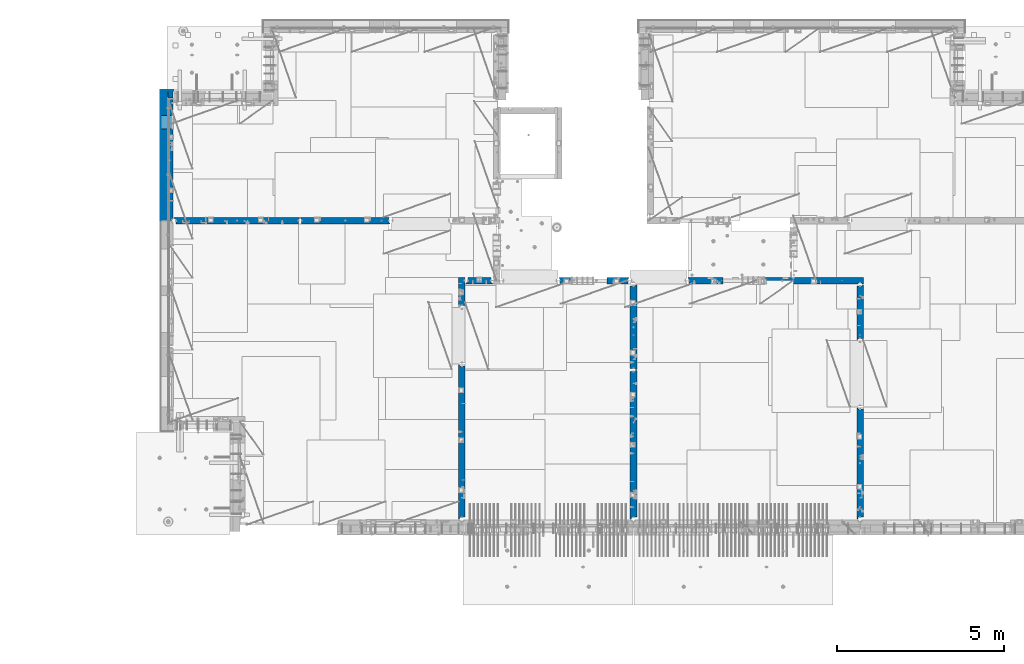
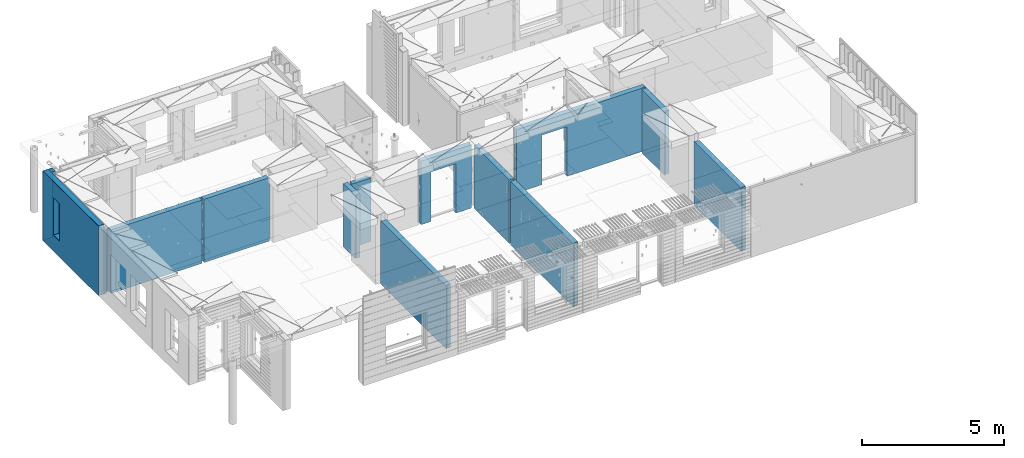
# One storey, part 200 of 309: 16 walls, 12 elements without a shape of their own.
"""IFC2X3 building model written with IfcOpenShell, lengths in millimetres."""

from ifc_helpers import new_model, si_unit, frame, origin_with_axes, place, context, subcontext, project, spatial, faceted_brep, material, type_object, element, aggregate, save


model = new_model("IFC2X3")

# Units and contexts
model_context = context("Model", 3, precision=1e-05, world=origin_with_axes())
body_context = subcontext(model_context, "Body", "Model", "MODEL_VIEW")
ifc_project = project(units=[si_unit("LENGTHUNIT", "METRE", prefix="MILLI"), si_unit("AREAUNIT", "SQUARE_METRE"), si_unit("VOLUMEUNIT", "CUBIC_METRE"), si_unit("MASSUNIT", "GRAM", prefix="KILO"), si_unit("TIMEUNIT", "SECOND"), si_unit("PLANEANGLEUNIT", "RADIAN"), si_unit("SOLIDANGLEUNIT", "STERADIAN"), si_unit("THERMODYNAMICTEMPERATUREUNIT", "DEGREE_CELSIUS"), si_unit("LUMINOUSINTENSITYUNIT", "LUMEN")], contexts=[model_context])

# Site, building, storey
site_placement = place(None, origin_with_axes())
site = spatial("IfcSite", under=ifc_project, at=site_placement, CompositionType="ELEMENT")
building_placement = place(site_placement, origin_with_axes())
building = spatial("IfcBuilding", under=site, at=building_placement, CompositionType="ELEMENT")
storey_placement = place(building_placement, origin_with_axes())
storey = spatial("IfcBuildingStorey", under=building, at=storey_placement, Name="7", CompositionType="ELEMENT", Elevation=0.0)

# Assembly, wall
assembly_1_placement = place(storey_placement, origin_with_axes())
assembly_1 = element("IfcElementAssembly", 1, at=assembly_1_placement, inside=storey, AssemblyPlace="NOTDEFINED", PredefinedType="REINFORCEMENT_UNIT")
ifc_material_1 = material(Name="CONCRETE/C25/30")
wall_type_1 = type_object("IfcWallType", PredefinedType="NOTDEFINED")
wall_1_placement = place(assembly_1_placement, frame((28610.0, 13387.9996249472, 101112.5), z_axis=(0.0, 0.0, 1.0), x_axis=(0.0, 1.0, 0.0)))
wall_1 = element("IfcWall", 2, at=wall_1_placement, type_object=wall_type_1, material=ifc_material_1, context=body_context, shape_type="Brep", body=[
    faceted_brep([(30.9999999999982, 70.0000000000073, 1357.5), (30.9999999999982, 70.0000000000073, -1357.5), (60.9999999999982, 57.0000000000036, -1357.5), (60.9999999999982, 57.0000000000036, 1357.5), (60.9999999999982, -100.0, 1357.5), (60.9999999999982, -100.0, -1357.5), (30.9999999999982, 100.0, -1357.5), (30.9999999999982, 100.0, 1357.5), (1631.00037505278, 100.0, 1357.5), (1631.00037505278, 100.0, -1357.5), (1631.00037505278, -56.9999999999964, 1357.5), (1631.00037505278, -56.9999999999964, -1357.5), (1661.00037505278, -70.0, 1357.5), (1661.00037505278, -70.0, -1357.5), (1661.00037505278, -100.0, 1357.5), (1661.00037505278, -100.0, -1357.5)], [[[0, 1, 2, 3]], [[4, 3, 2, 5]], [[6, 7, 8, 9]], [[10, 11, 9, 8]], [[12, 13, 11, 10]], [[14, 15, 13, 12]], [[15, 14, 4, 5]], [[1, 6, 9, 11, 13, 15, 5, 2]], [[7, 6, 1, 0]], [[14, 12, 10, 8, 7, 0, 3, 4]]]),
])
aggregate(assembly_1, [wall_1])

assembly_2_placement = place(storey_placement, origin_with_axes())
assembly_2 = element("IfcElementAssembly", 3, at=assembly_2_placement, inside=storey, AssemblyPlace="NOTDEFINED", PredefinedType="REINFORCEMENT_UNIT")
wall_2_placement = place(assembly_2_placement, frame((28610.0, 8000.0, 101112.5), z_axis=(0.0, 0.0, 1.0), x_axis=(0.0, 1.0, 0.0)))
wall_2 = element("IfcWall", 4, at=wall_2_placement, type_object=wall_type_1, material=ifc_material_1, context=body_context, shape_type="Brep", body=[
    faceted_brep([(30.0000000000009, 70.0, 1357.5), (30.0, 70.0, -1357.5), (80.0, 57.0, -1357.5), (79.99999955967, 57.0000001052285, 1357.5), (79.9999996695051, -100.0, 1357.5), (80.0, -100.0, -1357.5), (30.0, 100.0, -1357.5), (30.0000000000009, 100.0, 1357.5), (3360.0, 100.0, 1357.5), (3360.0, 100.0, -1357.5), (3360.0, 70.0000000000073, 1357.5), (3360.0, 70.0000000000073, -1357.5), (3330.0, 57.0000000000036, 1357.5), (3330.0, 57.0000000000036, -1357.5), (3330.0, -100.0, 1357.5), (3330.0, -100.0, -1357.5)], [[[0, 1, 2, 3]], [[4, 3, 2, 5]], [[6, 7, 8, 9]], [[9, 8, 10, 11]], [[12, 13, 11, 10]], [[14, 15, 13, 12]], [[15, 14, 4, 5]], [[1, 6, 9, 11, 13, 15, 5, 2]], [[7, 6, 1, 0]], [[14, 12, 10, 8, 7, 0, 3, 4]]]),
])
aggregate(assembly_2, [wall_2])

assembly_3_placement = place(storey_placement, origin_with_axes())
assembly_3 = element("IfcElementAssembly", 5, at=assembly_3_placement, inside=storey, AssemblyPlace="NOTDEFINED", PredefinedType="REINFORCEMENT_UNIT")
wall_3_placement = place(assembly_3_placement, frame((23410.0002919986, 15180.0, 101112.5), z_axis=(0.0, 0.0, 1.0), x_axis=(1.0, 0.0, 0.0)))
wall_3 = element("IfcWall", 6, at=wall_3_placement, type_object=wall_type_1, material=ifc_material_1, context=body_context, shape_type="Brep", body=[
    faceted_brep([(3134.99885559082, 100.0, 762.5), (3147.99885559082, 80.0, 762.5), (3251.99885559082, 80.0, 762.5), (3264.99885559082, 100.0, 762.5), (3147.99885559082, 80.0, 1357.5), (3134.99885559082, 100.0, 1357.5), (3251.99885559082, 80.0, 1357.5), (3264.99885559082, 100.0, 1357.5), (5299.99970800144, -100.0, -1357.5), (5299.99970800144, -100.0, 1357.5), (5264.99970800144, -100.0, 1357.5), (5264.99970800144, -100.0, -1357.5), (5251.99970800144, -70.0, 1357.5), (5251.99970800144, -70.0, -1357.5), (5147.99970800144, -70.0, 1357.5), (5147.99970800144, -70.0, -1357.5), (5134.99970800144, -100.0, 1357.5), (5134.99970800144, -100.0, -1357.5), (59.9988535092562, -100.0, 1357.5), (59.9988535092562, -100.0, -1357.5), (1090.00039464695, -100.0, -1357.5), (1090.00039464695, -100.0, 762.5), (2110.00039464695, -100.0, 762.5), (2110.00039464695, -100.0, -1357.5), (59.9988535092562, 57.0, 1357.5), (59.9988535092562, 57.0, -1357.5), (29.9988535092562, 70.0000000000018, 1357.5), (29.9988535092562, 70.0000000000018, -1357.5), (29.9988535092562, 100.0, 1357.5), (29.9988535092562, 100.0, -1357.5), (1090.00039464695, 100.0, -1357.5), (1090.00039464695, 100.0, 762.5), (2110.00039464695, 100.0, 762.5), (2110.00039464695, 100.0, -1357.5), (5299.99970800144, 100.0, -1357.5), (5299.99970800144, 100.0, 1357.5)], [[[0, 1, 2, 3]], [[4, 1, 0, 5]], [[6, 2, 1, 4]], [[7, 3, 2, 6]], [[8, 9, 10, 11]], [[10, 12, 13, 11]], [[14, 15, 13, 12]], [[16, 17, 15, 14]], [[17, 16, 18, 19, 20, 21, 22, 23]], [[24, 25, 19, 18]], [[26, 27, 25, 24]], [[28, 29, 27, 26]], [[19, 25, 27, 29, 30, 20]], [[31, 21, 20, 30]], [[32, 22, 21, 31]], [[33, 23, 22, 32]], [[34, 8, 11, 13, 15, 17, 23, 33]], [[9, 8, 34, 35]], [[4, 5, 28, 26, 24, 18, 16, 14, 12, 10, 9, 35, 7, 6]], [[35, 34, 33, 32, 31, 30, 29, 28, 5, 0, 3, 7]]]),
])
aggregate(assembly_3, [wall_3])

assembly_4_placement = place(storey_placement, origin_with_axes())
assembly_4 = element("IfcElementAssembly", 7, at=assembly_4_placement, inside=storey, AssemblyPlace="NOTDEFINED", PredefinedType="REINFORCEMENT_UNIT")
wall_4_placement = place(assembly_4_placement, frame((21810.0, 12500.0, 101112.5), z_axis=(0.0, 0.0, 1.0), x_axis=(0.0, 1.0, 0.0)))
wall_4 = element("IfcWall", 8, at=wall_4_placement, type_object=wall_type_1, material=ifc_material_1, context=body_context, shape_type="Brep", body=[
    faceted_brep([(2519.9998239177, -57.0, 1357.5), (2519.9998239177, -57.0, -1357.5), (2519.9998239177, 100.0, -1357.5), (2519.9998239177, 100.0, 1357.5), (2549.9998239177, -70.0, 1357.5), (2549.9998239177, -70.0, -1357.5), (45.0, 100.0, 1357.5), (45.0, 100.0, -1357.5), (45.0, -57.0, -1357.5), (45.0, -57.0, 1357.5), (15.0, -70.0, 1357.5), (15.0, -70.0000000000036, -1357.5), (15.0, -100.0, -1357.5), (15.0, -100.0, 1357.5), (2549.9998239177, -100.0, -1357.5), (2549.9998239177, -100.0, 1357.5)], [[[0, 1, 2, 3]], [[4, 5, 1, 0]], [[6, 7, 8, 9]], [[10, 9, 8, 11]], [[12, 13, 10, 11]], [[13, 12, 14, 15]], [[3, 6, 9, 10, 13, 15, 4, 0]], [[7, 6, 3, 2]], [[14, 12, 11, 8, 7, 2, 1, 5]], [[15, 14, 5, 4]]]),
])
aggregate(assembly_4, [wall_4])

assembly_5_placement = place(storey_placement, origin_with_axes())
assembly_5 = element("IfcElementAssembly", 9, at=assembly_5_placement, inside=storey, AssemblyPlace="NOTDEFINED", PredefinedType="REINFORCEMENT_UNIT")
wall_5_placement = place(assembly_5_placement, frame((21810.0, 8000.0, 101112.5), z_axis=(0.0, 0.0, 1.0), x_axis=(0.0, 1.0, 0.0)))
wall_5 = element("IfcWall", 10, at=wall_5_placement, type_object=wall_type_1, material=ifc_material_1, context=body_context, shape_type="Brep", body=[
    faceted_brep([(30.0000000000009, 70.0, 1357.5), (30.0, 70.0, -1357.5), (80.0, 57.0, -1357.5), (79.99999955967, 57.0000001052285, 1357.5), (79.9999996695051, -100.0, 1357.5), (80.0, -100.0, -1357.5), (30.0, 100.0, -1357.5), (30.0000000000009, 100.0, 1357.5), (4455.0, 100.0, 1357.5), (4455.0, 100.0, -1357.5), (4455.0, -57.0, 1357.5), (4455.0, -57.0, -1357.5), (4485.0, -70.0000000000036, 1357.5), (4485.0, -70.0000000000036, -1357.5), (4485.0, -100.0, 1357.5), (4485.0, -100.0, -1357.5)], [[[0, 1, 2, 3]], [[4, 3, 2, 5]], [[6, 7, 8, 9]], [[10, 11, 9, 8]], [[12, 13, 11, 10]], [[14, 15, 13, 12]], [[15, 14, 4, 5]], [[1, 6, 9, 11, 13, 15, 5, 2]], [[7, 6, 1, 0]], [[14, 12, 10, 8, 7, 0, 3, 4]]]),
])
aggregate(assembly_5, [wall_5])

assembly_6_placement = place(storey_placement, origin_with_axes())
assembly_6 = element("IfcElementAssembly", 11, at=assembly_6_placement, inside=storey, AssemblyPlace="NOTDEFINED", PredefinedType="REINFORCEMENT_UNIT")
wall_6_placement = place(assembly_6_placement, frame((19569.9991455076, 15180.0000000001, 101112.5), z_axis=(0.0, 0.0, 1.0), x_axis=(1.0, 0.0, 0.0)))
wall_6 = element("IfcWall", 12, at=wall_6_placement, type_object=wall_type_1, material=ifc_material_1, context=body_context, shape_type="Brep", body=[
    faceted_brep([(30.0000000001819, 56.9999999999745, 1357.5), (30.0000000001819, 56.9999999999745, -1357.5), (30.0000000001819, -100.0, -1357.5), (30.0000000001819, -100.0, 1357.5), (0.0, 69.9999999999745, 1357.5), (0.0, 69.9999999999745, -1357.5), (1450.00154113788, 100.0, -1357.5), (1450.00154113788, -100.0, -1357.5), (1450.00154113788, -100.0, 762.5), (1450.00154113788, 100.0, 762.5), (430.001541137881, 100.0, 762.5), (430.001541137881, -100.0, 762.5), (430.001541137881, -100.0, -1357.5), (430.001541137881, 100.0, -1357.5), (0.0, 100.0, -1357.5), (0.0, 100.0, 1357.5), (2110.00085449221, 100.0, 1357.5), (2110.00085449221, 100.0, -1357.5), (2110.00085449272, 70.0000000037435, 1357.5), (2110.00085449221, 70.0000000037435, -1357.5), (2080.00085191853, -100.0, -1357.5), (2080.00085558004, 57.0000004585763, -1357.5), (2080.00085558004, 57.0000004585763, 1357.5), (2080.00085191853, -100.0, 1357.5)], [[[0, 1, 2, 3]], [[4, 5, 1, 0]], [[6, 7, 8, 9]], [[10, 11, 12, 13]], [[9, 8, 11, 10]], [[13, 14, 15, 16, 17, 6, 9, 10]], [[17, 16, 18, 19]], [[20, 7, 6, 17, 19, 21]], [[18, 22, 21, 19]], [[23, 20, 21, 22]], [[12, 11, 8, 7, 20, 23, 3, 2]], [[14, 13, 12, 2, 1, 5]], [[15, 14, 5, 4]], [[23, 22, 18, 16, 15, 4, 0, 3]]]),
])
aggregate(assembly_6, [wall_6])

assembly_7_placement = place(storey_placement, origin_with_axes())
assembly_7 = element("IfcElementAssembly", 13, at=assembly_7_placement, inside=storey, AssemblyPlace="NOTDEFINED", PredefinedType="REINFORCEMENT_UNIT")
wall_7_placement = place(assembly_7_placement, frame((16660.0, 8000.0, 101112.5), z_axis=(0.0, 0.0, 1.0), x_axis=(0.0, 1.0, 0.0)))
wall_7 = element("IfcWall", 14, at=wall_7_placement, type_object=wall_type_1, material=ifc_material_1, context=body_context, shape_type="Brep", body=[
    faceted_brep([(30.0000000000009, 70.0, 1357.5), (30.0, 70.0, -1357.5), (80.0, 57.0, -1357.5), (79.99999955967, 57.0000001052285, 1357.5), (79.9999996695051, -100.0, 1357.5), (80.0, -100.0, -1357.5), (30.0, 100.0, -1357.5), (30.0000000000009, 100.0, 1357.5), (4644.99239711402, 100.0, 1357.5), (4644.99239711402, 100.0, -1357.5), (4644.99653549905, 70.0145277302508, 1357.5), (4644.99653549905, 70.0145277302508, -1357.5), (4614.97833252975, 57.001718635147, 1357.5), (4614.97833252975, 57.001718635147, -1357.5), (4615.00000080787, -100.0, 1357.5), (4615.00000080787, -100.0, -1357.5)], [[[0, 1, 2, 3]], [[4, 3, 2, 5]], [[6, 7, 8, 9]], [[9, 8, 10, 11]], [[12, 13, 11, 10]], [[14, 15, 13, 12]], [[15, 14, 4, 5]], [[1, 6, 9, 11, 13, 15, 5, 2]], [[7, 6, 1, 0]], [[14, 12, 10, 8, 7, 0, 3, 4]]]),
])
aggregate(assembly_7, [wall_7])

assembly_8_placement = place(storey_placement, origin_with_axes())
assembly_8 = element("IfcElementAssembly", 15, at=assembly_8_placement, inside=storey, AssemblyPlace="NOTDEFINED", PredefinedType="REINFORCEMENT_UNIT")
wall_8_placement = place(assembly_8_placement, frame((16660.0, 14375.0001284873, 101112.5), z_axis=(0.0, 0.0, 1.0), x_axis=(0.0, 1.0, 0.0)))
wall_8 = element("IfcWall", 16, at=wall_8_placement, type_object=wall_type_1, material=ifc_material_1, context=body_context, shape_type="Brep", body=[
    faceted_brep([(59.9783637637502, 57.008280238686, -607.5), (29.9765698802239, 70.004139724977, -607.5), (29.972430061518, 100.0, -607.5), (84.972430061518, 100.0, -607.5), (84.972430061518, 50.0, -607.5), (59.9793309975266, 50.0, -607.5), (84.972430061518, 50.0, -1357.5), (84.972430061518, 100.0, -1357.5), (59.9793309975285, 50.0, -1357.5), (739.999871512746, -100.0, 1357.5), (752.999871512742, -80.0, 1357.5), (856.999871512742, -80.0, 1357.5), (869.99987151274, -100.0, 1357.5), (904.999871512742, -100.0, 1357.5), (904.999871512742, 100.0, 1357.5), (29.972430061518, 100.0, 1357.5), (29.9765698802239, 70.004139724977, 1357.5), (59.9783637637502, 57.008280238686, 1357.5), (60.0000329474624, -100.0, 1357.5), (739.999871512746, -100.0, -1357.5), (60.0000329474624, -100.0, -1357.5), (752.999871512742, -80.0, -1357.5), (856.999871512742, -80.0, -1357.5), (869.99987151274, -100.0, -1357.5), (904.999871512742, -100.0, -1357.5), (904.999871512742, 100.0, -1357.5)], [[[0, 1, 2, 3, 4, 5]], [[6, 4, 3, 7]], [[8, 5, 4, 6]], [[9, 10, 11, 12, 13, 14, 15, 16, 17, 18]], [[19, 9, 18, 20]], [[9, 19, 21, 10]], [[10, 21, 22, 11]], [[12, 11, 22, 23]], [[24, 13, 12, 23]], [[13, 24, 25, 14]], [[15, 14, 25, 7, 3, 2]], [[16, 15, 2, 1]], [[17, 16, 1, 0]], [[20, 18, 17, 0, 5, 8]], [[25, 24, 23, 22, 21, 19, 20, 8, 6, 7]]]),
])
aggregate(assembly_8, [wall_8])

assembly_9_placement = place(storey_placement, origin_with_axes())
assembly_9 = element("IfcElementAssembly", 17, at=assembly_9_placement, inside=storey, AssemblyPlace="NOTDEFINED", PredefinedType="REINFORCEMENT_UNIT")
wall_9_placement = place(assembly_9_placement, frame((16790.0, 15180.0, 101112.5), z_axis=(0.0, 0.0, 1.0), x_axis=(1.0, 0.0, 0.0)))
wall_9 = element("IfcWall", 18, at=wall_9_placement, type_object=wall_type_1, material=ifc_material_1, context=body_context, shape_type="Brep", body=[
    faceted_brep([(740.0, 100.0, 1357.5), (740.0, -57.0, 1357.5), (740.0, -57.0, -1357.5), (740.0, 100.0, -1357.5), (790.0, -70.0, 1357.5), (790.0, -69.9999999999982, -1357.5), (50.0, 100.0, 1357.5), (50.0, 100.0, -1357.5), (50.0, -48.3299999999999, -1357.5), (50.0, -48.3299999999999, 1357.5), (0.0, -69.996666666666, -1357.5), (0.0, -69.996666666666, 1357.5), (0.0, -100.0, -1357.5), (0.0, -100.0, 1357.5), (790.0, -100.0, -1357.5), (790.0, -100.0, 1357.5)], [[[0, 1, 2, 3]], [[4, 5, 2, 1]], [[6, 7, 8, 9]], [[9, 8, 10, 11]], [[12, 13, 11, 10]], [[13, 12, 14, 15]], [[1, 0, 6, 9, 11, 13, 15, 4]], [[7, 6, 0, 3]], [[14, 12, 10, 8, 7, 3, 2, 5]], [[15, 14, 5, 4]]]),
])
aggregate(assembly_9, [wall_9])

assembly_10_placement = place(storey_placement, origin_with_axes())
assembly_10 = element("IfcElementAssembly", 19, at=assembly_10_placement, inside=storey, AssemblyPlace="NOTDEFINED", PredefinedType="REINFORCEMENT_UNIT")
wall_10_placement = place(assembly_10_placement, frame((11795.0, 16980.0, 101112.5), z_axis=(0.0, 0.0, 1.0), x_axis=(1.0, 0.0, 0.0)))
wall_10 = element("IfcWall", 20, at=wall_10_placement, type_object=wall_type_1, material=ifc_material_1, context=body_context, shape_type="Brep", body=[
    faceted_brep([(2680.0, 100.0, 1357.5), (2680.0, -57.0, 1357.5), (2680.0, -57.0, -1357.50000000001), (2680.0, 100.0, -1357.5), (2705.0, -67.8333333333321, 1357.5), (2705.0, -67.8333333333321, -1357.5), (25.0, 100.0, 1357.5), (25.0, 100.0, -1357.5), (25.0, 70.0000000000036, -1357.5), (25.0, 70.0000000000036, 1357.5), (55.0, 57.0, -1357.5), (55.0, 57.0, 1357.5), (55.0, -100.0, -1357.5), (55.0, -100.0, 1357.5), (2705.0, -100.0, -1357.5), (2705.0, -100.0, 1357.5)], [[[0, 1, 2, 3]], [[4, 5, 2, 1]], [[6, 7, 8, 9]], [[9, 8, 10, 11]], [[11, 10, 12, 13]], [[14, 15, 13, 12]], [[0, 6, 9, 11, 13, 15, 4, 1]], [[7, 6, 0, 3]], [[14, 12, 10, 8, 7, 3, 2, 5]], [[15, 14, 5, 4]]]),
])
aggregate(assembly_10, [wall_10])

assembly_11_placement = place(storey_placement, origin_with_axes())
assembly_11 = element("IfcElementAssembly", 21, at=assembly_11_placement, inside=storey, AssemblyPlace="NOTDEFINED", PredefinedType="REINFORCEMENT_UNIT")
wall_11_placement = place(assembly_11_placement, frame((8000.0, 16980.0, 101112.5), z_axis=(0.0, 0.0, 1.0), x_axis=(1.0, 0.0, 0.0)))
wall_11 = element("IfcWall", 22, at=wall_11_placement, type_object=wall_type_1, material=ifc_material_1, context=body_context, shape_type="Brep", body=[
    faceted_brep([(80.0, 52.0, 1357.5), (80.0, 52.0, -1357.5), (80.0, -100.0, -1357.5), (79.9999996695051, -100.0, 1357.5), (30.0000022791291, 65.0, 1357.5), (30.0000022791291, 65.0, -1357.5), (30.0, 100.0, -1357.5), (30.0000000000009, 100.0, 1357.5), (3790.0, 100.0, 1357.5), (3790.0, 100.0, -1357.5), (3790.0, 70.0000000000036, 1357.5), (3790.0, 70.0000000000036, -1357.5), (3760.0, 57.0, 1357.5), (3760.0, 57.0, -1357.5), (3760.0, -100.0, 1357.5), (3760.0, -100.0, -1357.5)], [[[0, 1, 2, 3]], [[4, 5, 1, 0]], [[6, 7, 8, 9]], [[9, 8, 10, 11]], [[10, 12, 13, 11]], [[14, 15, 13, 12]], [[15, 14, 3, 2]], [[6, 9, 11, 13, 15, 2, 1, 5]], [[7, 6, 5, 4]], [[14, 12, 10, 8, 7, 4, 0, 3]]]),
])
aggregate(assembly_11, [wall_11])

# Assembly, walls
assembly_12_placement = place(storey_placement, origin_with_axes())
assembly_12 = element("IfcElementAssembly", 23, at=assembly_12_placement, inside=storey, AssemblyPlace="NOTDEFINED", PredefinedType="REINFORCEMENT_UNIT")
ifc_material_2 = material()
wall_type_2 = type_object("IfcWallType", PredefinedType="NOTDEFINED")
wall_12_placement = place(assembly_12_placement, frame((7850.0, 20764.9951872276, 101247.5), z_axis=(0.0, 0.0, 1.0), x_axis=(1.0, 0.0, 0.0)))
wall_12 = element("IfcWall", 24, at=wall_12_placement, type_object=wall_type_2, material=ifc_material_2, context=body_context, shape_type="Brep", body=[
    faceted_brep([(0.0, 110.0, -1492.5), (0.0, 110.0, 1492.5), (150.0, 110.0, 1492.5), (150.0, 110.0, -1492.5), (0.0, -110.0, 1492.5), (150.0, -110.0, 1492.5), (0.0, -110.0, -1492.5), (150.0, -110.0, -1492.5)], [[[0, 1, 2, 3]], [[1, 4, 5, 2]], [[4, 6, 7, 5]], [[6, 0, 3, 7]], [[5, 7, 3, 2]], [[6, 4, 1, 0]]]),
])
wall_13_placement = place(assembly_12_placement, frame((7740.0, 16980.0, 101247.5), z_axis=(0.0, 0.0, 1.0), x_axis=(0.0, 1.0, 0.0)))
wall_13 = element("IfcWall", 25, at=wall_13_placement, type_object=wall_type_2, material=ifc_material_2, context=body_context, shape_type="Brep", body=[
    faceted_brep([(5.0, -110.0, 1492.5), (5.0, -110.0, -1492.5), (3894.99518722756, -110.0, -1492.5), (3894.99518722756, -110.0, 1492.5), (2745.00189658477, -110.0, -802.5), (2745.00189658477, -110.0, 807.5), (3155.00189658477, -110.0, 807.5), (3155.00189658477, -110.0, -802.5), (5.0, 110.0, 1492.5), (3894.99518722756, 110.0, 1492.5), (5.0, 110.0, -1492.5), (3894.99518722756, 110.0, -1492.5), (2745.00189658477, 110.0, -802.5), (3155.00189658477, 110.0, -802.5), (3155.00189658477, 110.0, 807.5), (2745.00189658477, 110.0, 807.5)], [[[0, 1, 2, 3], [4, 5, 6, 7]], [[8, 0, 3, 9]], [[1, 0, 8, 10]], [[1, 10, 11, 2]], [[3, 2, 11, 9]], [[10, 8, 9, 11], [12, 13, 14, 15]], [[6, 14, 13, 7]], [[5, 15, 14, 6]], [[4, 12, 15, 5]], [[7, 13, 12, 4]]]),
])
wall_type_3 = type_object("IfcWallType", PredefinedType="NOTDEFINED")
wall_14_placement = place(assembly_12_placement, frame((7925.0, 16980.0, 101112.5), z_axis=(0.0, 0.0, 1.0), x_axis=(0.0, 1.0, 0.0)))
wall_14 = element("IfcWall", 26, at=wall_14_placement, type_object=wall_type_3, material=ifc_material_1, context=body_context, shape_type="Brep", body=[
    faceted_brep([(3155.00189658477, -74.9999998692319, -667.5), (3155.00189658477, 75.0, -667.5), (2745.00189658477, 75.0, -667.5), (2745.00189658477, -74.9999999986567, -667.5), (2745.00189658477, 75.0, 942.5), (2745.00189658477, -75.000000709987, 942.5), (3155.00189658477, 75.0, 942.5), (3155.00189658477, -75.0000005805623, 942.5), (3674.99518722756, -75.0, -1357.5), (3674.99518722756, -75.0, 1357.5), (3564.99519001209, -75.0000022791282, 1357.5), (3564.99519001209, -75.0, -1357.5), (3674.99518722756, 75.0, 1357.5), (5.0, 75.0, 1357.5), (5.0, -15.0000022791291, 1357.5), (65.0, -75.0, 1357.5), (3484.99518722756, -75.0000001199542, 1357.5), (3497.99518763813, -54.9999993903657, 1357.5), (3551.99518754267, -54.9999994175314, 1357.5), (5.0, 75.0, -1357.5), (5.0, -15.0000022791291, -1357.5), (65.0, -75.0, -1357.5), (3484.99518722756, -75.0, -1357.5), (3497.99518763813, -54.9999993903657, -1357.5), (3551.99518754267, -54.9999994175314, -1357.5), (3674.99518722756, 75.0, -1357.5)], [[[0, 1, 2, 3]], [[3, 2, 4, 5]], [[5, 4, 6, 7]], [[7, 6, 1, 0]], [[8, 9, 10, 11]], [[9, 12, 13, 14, 15, 16, 17, 18, 10]], [[13, 19, 20, 14]], [[15, 14, 20, 21]], [[15, 21, 22, 16], [3, 5, 7, 0]], [[16, 22, 23, 17]], [[17, 23, 24, 18]], [[10, 18, 24, 11]], [[23, 22, 21, 20, 19, 25, 8, 11, 24]], [[9, 8, 25, 12]], [[19, 13, 12, 25], [2, 1, 6, 4]]]),
])
ifc_material_3 = material(Name="CONCRETE/C30/37")
wall_type_4 = type_object("IfcWallType", PredefinedType="NOTDEFINED")
wall_15_placement = place(assembly_12_placement, frame((7630.0, 20879.9952125549, 101247.5), z_axis=(0.0, 0.0, 1.0), x_axis=(1.0, 0.0, 0.0)))
wall_15 = element("IfcWall", 27, at=wall_15_placement, type_object=wall_type_4, material=ifc_material_3, context=body_context, shape_type="Brep", body=[
    faceted_brep([(0.0, 5.0, -1492.5), (0.0, 5.0, 1492.5), (370.0, 5.0, 1492.5), (370.0, 5.0, -1492.5), (0.0, -5.0, 1492.5), (370.0, -5.0, 1492.5), (0.0, -5.0, -1492.5), (370.0, -5.0, -1492.5)], [[[0, 1, 2, 3]], [[1, 4, 5, 2]], [[4, 6, 7, 5]], [[6, 0, 3, 7]], [[5, 7, 3, 2]], [[6, 4, 1, 0]]]),
])
wall_16_placement = place(assembly_12_placement, frame((7625.0, 16980.0, 101247.5), z_axis=(0.0, 0.0, 1.0), x_axis=(0.0, 1.0, 0.0)))
wall_16 = element("IfcWall", 28, at=wall_16_placement, type_object=wall_type_4, material=ifc_material_3, context=body_context, shape_type="Brep", body=[
    faceted_brep([(5.0, -5.0, 1492.5), (5.0, -5.0, -1492.5), (3904.99518722756, -5.0, -1492.5), (3904.99518722756, -5.0, 1492.5), (2745.00189658477, -5.0, -802.5), (2745.00189658477, -5.0, 807.5), (3155.00189658477, -5.0, 807.5), (3155.00189658477, -5.0, -802.5), (5.0, 5.0, 1492.5), (3904.99518722756, 5.0, 1492.5), (5.0, 5.0, -1492.5), (3904.99518722756, 5.0, -1492.5), (2745.00189658477, 5.0, -802.5), (3155.00189658477, 5.0, -802.5), (3155.00189658477, 5.0, 807.5), (2745.00189658477, 5.0, 807.5)], [[[0, 1, 2, 3], [4, 5, 6, 7]], [[8, 0, 3, 9]], [[1, 0, 8, 10]], [[1, 10, 11, 2]], [[3, 2, 11, 9]], [[10, 8, 9, 11], [12, 13, 14, 15]], [[6, 14, 13, 7]], [[5, 15, 14, 6]], [[4, 12, 15, 5]], [[7, 13, 12, 4]]]),
])
aggregate(assembly_12, [wall_12, wall_15, wall_13, wall_16, wall_14])

save(model, "model.ifc")
